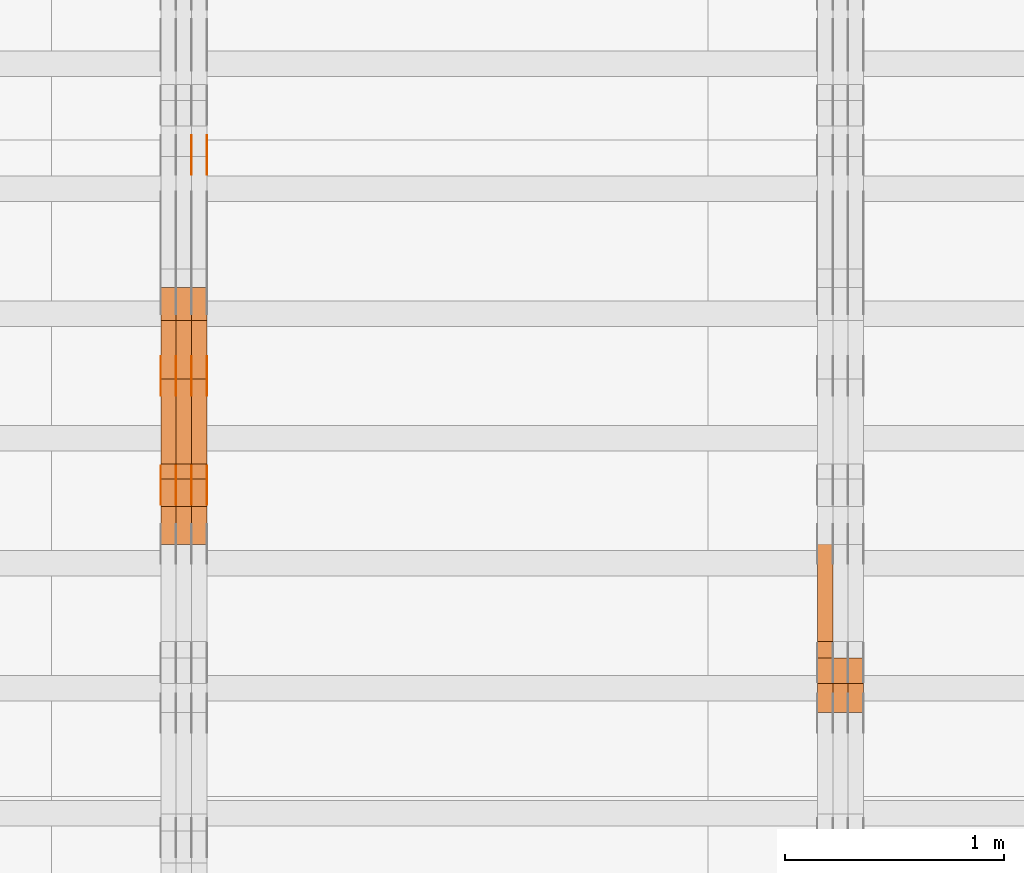
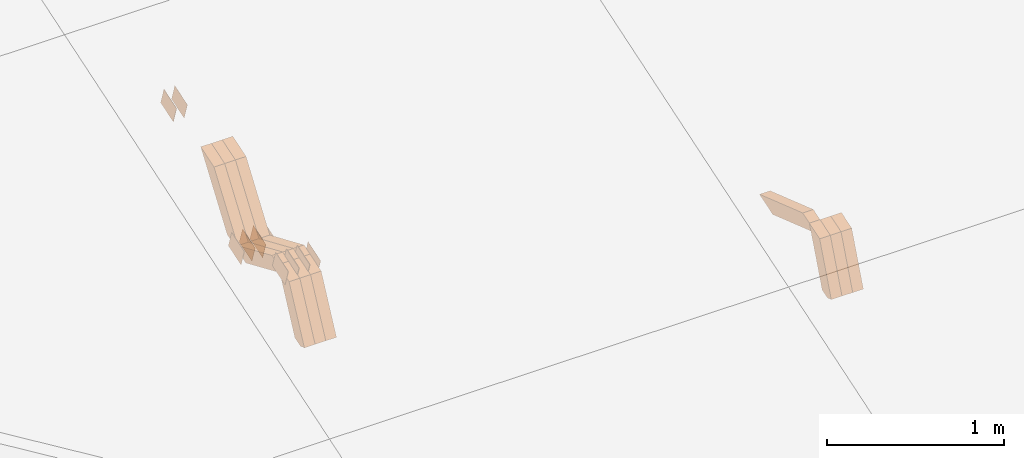
# One storey, part 270 of 385: 28 proxies.
"""IFC2X3 building model written with IfcOpenShell, lengths in millimetres."""

from ifc_helpers import new_model, entity, si_unit, converted_unit, derived_unit, direction, frame, origin, place, context, subcontext, project, spatial, polyline, outline, extrude, source, transform, mapped, material, type_object, type_shapes, element, save


model = new_model("IFC2X3")

# Units and contexts
model_context = context("Model", 3, precision=0.01, world=origin(), true_north=direction((6.12303176911189e-17, 1.0)))
body_context = subcontext(model_context, "Body", "Model", "MODEL_VIEW")
ifc_project = project(units=[si_unit("LENGTHUNIT", "METRE", prefix="MILLI"), si_unit("AREAUNIT", "SQUARE_METRE"), si_unit("VOLUMEUNIT", "CUBIC_METRE"), converted_unit("PLANEANGLEUNIT", "DEGREE", entity("IfcRatioMeasure", 0.0174532925199433), si_unit("PLANEANGLEUNIT", "RADIAN"), dimensions=[0, 0, 0, 0, 0, 0, 0]), si_unit("MASSUNIT", "GRAM", prefix="KILO"), derived_unit("MASSDENSITYUNIT", [(si_unit("MASSUNIT", "GRAM", prefix="KILO"), 1), (si_unit("LENGTHUNIT", "METRE"), -3)]), si_unit("TIMEUNIT", "SECOND"), si_unit("FREQUENCYUNIT", "HERTZ"), si_unit("THERMODYNAMICTEMPERATUREUNIT", "DEGREE_CELSIUS"), derived_unit("THERMALTRANSMITTANCEUNIT", [(si_unit("MASSUNIT", "GRAM", prefix="KILO"), 1), (si_unit("THERMODYNAMICTEMPERATUREUNIT", "KELVIN"), -1), (si_unit("TIMEUNIT", "SECOND"), -3)]), derived_unit("VOLUMETRICFLOWRATEUNIT", [(si_unit("LENGTHUNIT", "METRE"), 3), (si_unit("TIMEUNIT", "SECOND"), -1)]), si_unit("ELECTRICCURRENTUNIT", "AMPERE"), si_unit("ELECTRICVOLTAGEUNIT", "VOLT"), si_unit("POWERUNIT", "WATT"), si_unit("FORCEUNIT", "NEWTON", prefix="KILO"), si_unit("ILLUMINANCEUNIT", "LUX"), si_unit("LUMINOUSFLUXUNIT", "LUMEN"), si_unit("LUMINOUSINTENSITYUNIT", "CANDELA"), derived_unit("USERDEFINED", [(si_unit("MASSUNIT", "GRAM", prefix="KILO"), -1), (si_unit("LENGTHUNIT", "METRE"), -2), (si_unit("TIMEUNIT", "SECOND"), 3), (si_unit("LUMINOUSFLUXUNIT", "LUMEN"), 1)]), derived_unit("LINEARVELOCITYUNIT", [(si_unit("LENGTHUNIT", "METRE"), 1), (si_unit("TIMEUNIT", "SECOND"), -1)]), si_unit("PRESSUREUNIT", "PASCAL"), derived_unit("USERDEFINED", [(si_unit("LENGTHUNIT", "METRE"), -2), (si_unit("MASSUNIT", "GRAM", prefix="KILO"), 1), (si_unit("TIMEUNIT", "SECOND"), -2)])], contexts=[model_context])

# Site, building, storey
site_placement = place(None, origin())
site = spatial("IfcSite", under=ifc_project, at=site_placement, CompositionType="ELEMENT")
building_placement = place(site_placement, origin())
building = spatial("IfcBuilding", under=site, at=building_placement, CompositionType="ELEMENT")
storey_placement = place(building_placement, origin())
storey = spatial("IfcBuildingStorey", under=building, at=storey_placement, Name="Default", CompositionType="ELEMENT", Elevation=0.0)

# Proxies
ifc_material_1 = material(Name="IfcSurfaceStyle #528020")
building_element_proxy_type_1 = type_object("IfcBuildingElementProxyType", Name="T1-W19 528018", PredefinedType="NOTDEFINED", material=ifc_material_1)
shared_shape_1 = source(origin(), body_context, "Body", "SweptSolid", [
    extrude(outline(polyline([(-234.986199656822, -47.5000587840676), (221.224626701627, -47.5000587840676), (219.29748584664, -9.04449542012076e-05), (156.014457007826, 47.5001040065446), (-361.550369899272, 47.5001040065447), (-234.986199656822, -47.5000587840676)])), frame((221.224626701627, 47.5001108598228, 0.0), z_axis=(0.0, 0.0, 1.0), x_axis=(-1.0, 0.0, 0.0)), (0.0, 0.0, 1.0), 70.0),
])
type_shapes(building_element_proxy_type_1, [shared_shape_1])
proxy_1_placement = place(building_placement, frame((45245.0, 6342.40425701111, 1541.63383639481), z_axis=(-1.0, 0.0, 0.0), x_axis=(0.0, 0.9461301511345, -0.323786561046329)))
element("IfcBuildingElementProxy", 1, at=proxy_1_placement, inside=storey, type_object=building_element_proxy_type_1, material=ifc_material_1, Name="T1-W19", context=body_context, shape_type="MappedRepresentation", body=[
    mapped(shared_shape_1, transform((0.0, 0.0, 0.0), scale=1.0)),
])
ifc_material_2 = material(Name="IfcSurfaceStyle #527756")
building_element_proxy_type_2 = type_object("IfcBuildingElementProxyType", Name="T1-W46 527754", PredefinedType="NOTDEFINED", material=ifc_material_2)
shared_shape_2 = source(origin(), body_context, "Body", "SweptSolid", [
    extrude(outline(polyline([(-272.224583017384, -47.5002947748381), (128.798007350946, -47.5002947748382), (167.560249082673, 0.000339032424879266), (170.567132940603, 47.500741369691), (-194.700806356838, 47.4995091475604), (-272.224583017384, -47.5002947748381)])), frame((170.567293182179, 47.5001659655231, 0.0), z_axis=(0.0, 0.0, 1.0), x_axis=(-1.0, 3.37347464168628e-06, 0.0)), (0.0, 0.0, 1.0), 70.0),
])
type_shapes(building_element_proxy_type_2, [shared_shape_2])
proxy_2_placement = place(building_placement, frame((45385.0, 6080.04687500001, 1117.66674804688), z_axis=(-1.0, 0.0, 0.0), x_axis=(0.0, 0.361885618189232, 0.93222250527854)))
element("IfcBuildingElementProxy", 2, at=proxy_2_placement, inside=storey, type_object=building_element_proxy_type_2, material=ifc_material_2, Name="T1-W46", context=body_context, shape_type="MappedRepresentation", body=[
    mapped(shared_shape_2, transform((0.0, 0.0, 0.0), scale=1.0)),
])
ifc_material_3 = material(Name="IfcSurfaceStyle #527690")
building_element_proxy_type_3 = type_object("IfcBuildingElementProxyType", Name="T1-W46 527688", PredefinedType="NOTDEFINED", material=ifc_material_3)
shared_shape_3 = source(origin(), body_context, "Body", "SweptSolid", [
    extrude(outline(polyline([(-272.224583017384, -47.5002947748381), (128.798007350946, -47.5002947748382), (167.560249082673, 0.000339032424879266), (170.567132940603, 47.500741369691), (-194.700806356838, 47.4995091475604), (-272.224583017384, -47.5002947748381)])), frame((170.567293182179, 47.5001659655231, 0.0), z_axis=(0.0, 0.0, 1.0), x_axis=(-1.0, 3.37347464168628e-06, 0.0)), (0.0, 0.0, 1.0), 70.0),
])
type_shapes(building_element_proxy_type_3, [shared_shape_3])
proxy_3_placement = place(building_placement, frame((45315.0, 6080.04687500001, 1117.66674804688), z_axis=(-1.0, 0.0, 0.0), x_axis=(0.0, 0.361885618189232, 0.93222250527854)))
element("IfcBuildingElementProxy", 3, at=proxy_3_placement, inside=storey, type_object=building_element_proxy_type_3, material=ifc_material_3, Name="T1-W46", context=body_context, shape_type="MappedRepresentation", body=[
    mapped(shared_shape_3, transform((0.0, 0.0, 0.0), scale=1.0)),
])
ifc_material_4 = material(Name="IfcSurfaceStyle #527624")
building_element_proxy_type_4 = type_object("IfcBuildingElementProxyType", Name="T1-W46 527622", PredefinedType="NOTDEFINED", material=ifc_material_4)
shared_shape_4 = source(origin(), body_context, "Body", "SweptSolid", [
    extrude(outline(polyline([(-272.224583017384, -47.5002947748381), (128.798007350946, -47.5002947748382), (167.560249082673, 0.000339032424879266), (170.567132940603, 47.500741369691), (-194.700806356838, 47.4995091475604), (-272.224583017384, -47.5002947748381)])), frame((170.567293182179, 47.5001659655231, 0.0), z_axis=(0.0, 0.0, 1.0), x_axis=(-1.0, 3.37347464168628e-06, 0.0)), (0.0, 0.0, 1.0), 70.0),
])
type_shapes(building_element_proxy_type_4, [shared_shape_4])
proxy_4_placement = place(building_placement, frame((45245.0, 6080.04687500001, 1117.66674804688), z_axis=(-1.0, 0.0, 0.0), x_axis=(0.0, 0.361885618189232, 0.93222250527854)))
element("IfcBuildingElementProxy", 4, at=proxy_4_placement, inside=storey, type_object=building_element_proxy_type_4, material=ifc_material_4, Name="T1-W46", context=body_context, shape_type="MappedRepresentation", body=[
    mapped(shared_shape_4, transform((0.0, 0.0, 0.0), scale=1.0)),
])
ifc_material_5 = material(Name="IfcSurfaceStyle #522790")
building_element_proxy_type_5 = type_object("IfcBuildingElementProxyType", PredefinedType="NOTDEFINED", material=ifc_material_5)
shared_shape_5 = source(origin(), body_context, "Body", "SweptSolid", [
    extrude(outline(polyline([(-74.9998565677179, -60.000059685226), (74.9998794200128, -60.000059685226), (74.9998565677179, 60.000059685226), (-74.9998794200128, 60.000059685226), (-74.9998565677179, -60.000059685226)])), frame((75.0001976720505, 60.000059685226, 0.0), z_axis=(0.0, 0.0, 1.0), x_axis=(-1.0, 0.0, 0.0)), (0.0, 0.0, 1.0), 1.3),
])
type_shapes(building_element_proxy_type_5, [shared_shape_5])
proxy_5_placement = place(building_placement, frame((42386.3, 8537.53090236182, 1950.11166041942), z_axis=(-1.0, 0.0, 0.0), x_axis=(0.0, 0.951056516295124, 0.309016994375039)))
element("IfcBuildingElementProxy", 5, at=proxy_5_placement, inside=storey, type_object=building_element_proxy_type_5, material=ifc_material_5, context=body_context, shape_type="MappedRepresentation", body=[
    mapped(shared_shape_5, transform((0.0, 0.0, 0.0), scale=1.0)),
])
ifc_material_6 = material(Name="IfcSurfaceStyle #522733")
building_element_proxy_type_6 = type_object("IfcBuildingElementProxyType", PredefinedType="NOTDEFINED", material=ifc_material_6)
shared_shape_6 = source(origin(), body_context, "Body", "SweptSolid", [
    extrude(outline(polyline([(-74.9998565677179, -60.000059685226), (74.9998794200128, -60.000059685226), (74.9998565677179, 60.000059685226), (-74.9998794200128, 60.000059685226), (-74.9998565677179, -60.000059685226)])), frame((75.0001976720505, 60.000059685226, 0.0), z_axis=(0.0, 0.0, 1.0), x_axis=(-1.0, 0.0, 0.0)), (0.0, 0.0, 1.0), 1.3),
])
type_shapes(building_element_proxy_type_6, [shared_shape_6])
proxy_6_placement = place(building_placement, frame((42315.0, 8537.53090236182, 1950.11166041942), z_axis=(-1.0, 0.0, 0.0), x_axis=(0.0, 0.951056516295124, 0.309016994375039)))
element("IfcBuildingElementProxy", 6, at=proxy_6_placement, inside=storey, type_object=building_element_proxy_type_6, material=ifc_material_6, context=body_context, shape_type="MappedRepresentation", body=[
    mapped(shared_shape_6, transform((0.0, 0.0, 0.0), scale=1.0)),
])
ifc_material_7 = material(Name="IfcSurfaceStyle #522676")
building_element_proxy_type_7 = type_object("IfcBuildingElementProxyType", PredefinedType="NOTDEFINED", material=ifc_material_7)
shared_shape_7 = source(origin(), body_context, "Body", "SweptSolid", [
    extrude(outline(polyline([(-74.9998565677179, -60.000059685226), (74.9998794200128, -60.000059685226), (74.9998565677179, 60.000059685226), (-74.9998794200128, 60.000059685226), (-74.9998565677179, -60.000059685226)])), frame((75.0001976720505, 60.000059685226, 0.0), z_axis=(0.0, 0.0, 1.0), x_axis=(-1.0, 0.0, 0.0)), (0.0, 0.0, 1.0), 1.3),
])
type_shapes(building_element_proxy_type_7, [shared_shape_7])
proxy_7_placement = place(building_placement, frame((42316.3, 8537.53090236182, 1950.11166041942), z_axis=(-1.0, 0.0, 0.0), x_axis=(0.0, 0.951056516295124, 0.309016994375039)))
element("IfcBuildingElementProxy", 7, at=proxy_7_placement, inside=storey, type_object=building_element_proxy_type_7, material=ifc_material_7, context=body_context, shape_type="MappedRepresentation", body=[
    mapped(shared_shape_7, transform((0.0, 0.0, 0.0), scale=1.0)),
])
ifc_material_8 = material(Name="IfcSurfaceStyle #517660")
building_element_proxy_type_8 = type_object("IfcBuildingElementProxyType", PredefinedType="NOTDEFINED", material=ifc_material_8)
shared_shape_8 = source(origin(), body_context, "Body", "SweptSolid", [
    extrude(outline(polyline([(-74.9998565677169, -60.0000596852269), (74.9998794200137, -60.0000596852269), (74.9998565677151, 60.0000596852269), (-74.9998794200119, 60.0000596852269), (-74.9998565677169, -60.0000596852269)])), frame((74.9998794200137, 60.0000596852269, 0.0), z_axis=(0.0, 0.0, 1.0), x_axis=(-1.0, 0.0, 0.0)), (0.0, 0.0, 1.0), 1.3),
])
type_shapes(building_element_proxy_type_8, [shared_shape_8])
proxy_8_placement = place(building_placement, frame((42386.3, 7527.6269081625, 1621.97418552253), z_axis=(-1.0, 0.0, 0.0), x_axis=(0.0, 0.951056516295124, 0.309016994375039)))
element("IfcBuildingElementProxy", 8, at=proxy_8_placement, inside=storey, type_object=building_element_proxy_type_8, material=ifc_material_8, context=body_context, shape_type="MappedRepresentation", body=[
    mapped(shared_shape_8, transform((0.0, 0.0, 0.0), scale=1.0)),
])
ifc_material_9 = material(Name="IfcSurfaceStyle #517603")
building_element_proxy_type_9 = type_object("IfcBuildingElementProxyType", PredefinedType="NOTDEFINED", material=ifc_material_9)
shared_shape_9 = source(origin(), body_context, "Body", "SweptSolid", [
    extrude(outline(polyline([(-74.9998565677169, -60.0000596852269), (74.9998794200137, -60.0000596852269), (74.9998565677151, 60.0000596852269), (-74.9998794200119, 60.0000596852269), (-74.9998565677169, -60.0000596852269)])), frame((74.9998794200137, 60.0000596852269, 0.0), z_axis=(0.0, 0.0, 1.0), x_axis=(-1.0, 0.0, 0.0)), (0.0, 0.0, 1.0), 1.3),
])
type_shapes(building_element_proxy_type_9, [shared_shape_9])
proxy_9_placement = place(building_placement, frame((42315.0, 7527.6269081625, 1621.97418552253), z_axis=(-1.0, 0.0, 0.0), x_axis=(0.0, 0.951056516295124, 0.309016994375039)))
element("IfcBuildingElementProxy", 9, at=proxy_9_placement, inside=storey, type_object=building_element_proxy_type_9, material=ifc_material_9, context=body_context, shape_type="MappedRepresentation", body=[
    mapped(shared_shape_9, transform((0.0, 0.0, 0.0), scale=1.0)),
])
ifc_material_10 = material(Name="IfcSurfaceStyle #517546")
building_element_proxy_type_10 = type_object("IfcBuildingElementProxyType", PredefinedType="NOTDEFINED", material=ifc_material_10)
shared_shape_10 = source(origin(), body_context, "Body", "SweptSolid", [
    extrude(outline(polyline([(-74.9998565677169, -60.0000596852269), (74.9998794200137, -60.0000596852269), (74.9998565677151, 60.0000596852269), (-74.9998794200119, 60.0000596852269), (-74.9998565677169, -60.0000596852269)])), frame((74.9998794200137, 60.0000596852269, 0.0), z_axis=(0.0, 0.0, 1.0), x_axis=(-1.0, 0.0, 0.0)), (0.0, 0.0, 1.0), 1.3),
])
type_shapes(building_element_proxy_type_10, [shared_shape_10])
proxy_10_placement = place(building_placement, frame((42316.3, 7527.6269081625, 1621.97418552253), z_axis=(-1.0, 0.0, 0.0), x_axis=(0.0, 0.951056516295124, 0.309016994375039)))
element("IfcBuildingElementProxy", 10, at=proxy_10_placement, inside=storey, type_object=building_element_proxy_type_10, material=ifc_material_10, context=body_context, shape_type="MappedRepresentation", body=[
    mapped(shared_shape_10, transform((0.0, 0.0, 0.0), scale=1.0)),
])
ifc_material_11 = material(Name="IfcSurfaceStyle #517489")
building_element_proxy_type_11 = type_object("IfcBuildingElementProxyType", PredefinedType="NOTDEFINED", material=ifc_material_11)
shared_shape_11 = source(origin(), body_context, "Body", "SweptSolid", [
    extrude(outline(polyline([(-74.9998565677169, -60.0000596852269), (74.9998794200137, -60.0000596852269), (74.9998565677151, 60.0000596852269), (-74.9998794200119, 60.0000596852269), (-74.9998565677169, -60.0000596852269)])), frame((74.9998794200137, 60.0000596852269, 0.0), z_axis=(0.0, 0.0, 1.0), x_axis=(-1.0, 0.0, 0.0)), (0.0, 0.0, 1.0), 1.29999999999999),
])
type_shapes(building_element_proxy_type_11, [shared_shape_11])
proxy_11_placement = place(building_placement, frame((42245.0, 7527.6269081625, 1621.97418552253), z_axis=(-1.0, 0.0, 0.0), x_axis=(0.0, 0.951056516295124, 0.309016994375039)))
element("IfcBuildingElementProxy", 11, at=proxy_11_placement, inside=storey, type_object=building_element_proxy_type_11, material=ifc_material_11, context=body_context, shape_type="MappedRepresentation", body=[
    mapped(shared_shape_11, transform((0.0, 0.0, 0.0), scale=1.0)),
])
ifc_material_12 = material(Name="IfcSurfaceStyle #517432")
building_element_proxy_type_12 = type_object("IfcBuildingElementProxyType", PredefinedType="NOTDEFINED", material=ifc_material_12)
shared_shape_12 = source(origin(), body_context, "Body", "SweptSolid", [
    extrude(outline(polyline([(-74.9998565677169, -60.0000596852269), (74.9998794200137, -60.0000596852269), (74.9998565677151, 60.0000596852269), (-74.9998794200119, 60.0000596852269), (-74.9998565677169, -60.0000596852269)])), frame((74.9998794200137, 60.0000596852269, 0.0), z_axis=(0.0, 0.0, 1.0), x_axis=(-1.0, 0.0, 0.0)), (0.0, 0.0, 1.0), 1.29999999999999),
])
type_shapes(building_element_proxy_type_12, [shared_shape_12])
proxy_12_placement = place(building_placement, frame((42246.3, 7527.6269081625, 1621.97418552253), z_axis=(-1.0, 0.0, 0.0), x_axis=(0.0, 0.951056516295124, 0.309016994375039)))
element("IfcBuildingElementProxy", 12, at=proxy_12_placement, inside=storey, type_object=building_element_proxy_type_12, material=ifc_material_12, context=body_context, shape_type="MappedRepresentation", body=[
    mapped(shared_shape_12, transform((0.0, 0.0, 0.0), scale=1.0)),
])
ifc_material_13 = material(Name="IfcSurfaceStyle #517375")
building_element_proxy_type_13 = type_object("IfcBuildingElementProxyType", PredefinedType="NOTDEFINED", material=ifc_material_13)
shared_shape_13 = source(origin(), body_context, "Body", "SweptSolid", [
    extrude(outline(polyline([(-74.9998565677169, -60.0000596852269), (74.9998794200137, -60.0000596852269), (74.9998565677151, 60.0000596852269), (-74.9998794200119, 60.0000596852269), (-74.9998565677169, -60.0000596852269)])), frame((74.9998794200137, 60.0000596852269, 0.0), z_axis=(0.0, 0.0, 1.0), x_axis=(-1.0, 0.0, 0.0)), (0.0, 0.0, 1.0), 1.29999999999999),
])
type_shapes(building_element_proxy_type_13, [shared_shape_13])
proxy_13_placement = place(building_placement, frame((42175.0, 7527.6269081625, 1621.97418552253), z_axis=(-1.0, 0.0, 0.0), x_axis=(0.0, 0.951056516295124, 0.309016994375039)))
element("IfcBuildingElementProxy", 13, at=proxy_13_placement, inside=storey, type_object=building_element_proxy_type_13, material=ifc_material_13, context=body_context, shape_type="MappedRepresentation", body=[
    mapped(shared_shape_13, transform((0.0, 0.0, 0.0), scale=1.0)),
])
ifc_material_14 = material(Name="IfcSurfaceStyle #507400")
building_element_proxy_type_14 = type_object("IfcBuildingElementProxyType", PredefinedType="NOTDEFINED", material=ifc_material_14)
shared_shape_14 = source(origin(), body_context, "Body", "SweptSolid", [
    extrude(outline(polyline([(-74.9998565677233, -60.0000596852342), (74.9998794200074, -60.0000596852342), (74.9998565677233, 60.0000596852342), (-74.9998794200074, 60.0000596852342), (-74.9998565677233, -60.0000596852342)])), frame((74.9998794200073, 60.0000596852342, 0.0), z_axis=(0.0, 0.0, 1.0), x_axis=(-1.0, 0.0, 0.0)), (0.0, 0.0, 1.0), 1.3),
])
type_shapes(building_element_proxy_type_14, [shared_shape_14])
proxy_14_placement = place(building_placement, frame((42386.3, 7029.15620503751, 1786.70025974129), z_axis=(-1.0, 0.0, 0.0), x_axis=(0.0, 0.951056516295154, 0.309016994374948)))
element("IfcBuildingElementProxy", 14, at=proxy_14_placement, inside=storey, type_object=building_element_proxy_type_14, material=ifc_material_14, context=body_context, shape_type="MappedRepresentation", body=[
    mapped(shared_shape_14, transform((0.0, 0.0, 0.0), scale=1.0)),
])
ifc_material_15 = material(Name="IfcSurfaceStyle #507343")
building_element_proxy_type_15 = type_object("IfcBuildingElementProxyType", PredefinedType="NOTDEFINED", material=ifc_material_15)
shared_shape_15 = source(origin(), body_context, "Body", "SweptSolid", [
    extrude(outline(polyline([(-74.9998565677233, -60.0000596852342), (74.9998794200074, -60.0000596852342), (74.9998565677233, 60.0000596852342), (-74.9998794200074, 60.0000596852342), (-74.9998565677233, -60.0000596852342)])), frame((74.9998794200073, 60.0000596852342, 0.0), z_axis=(0.0, 0.0, 1.0), x_axis=(-1.0, 0.0, 0.0)), (0.0, 0.0, 1.0), 1.3),
])
type_shapes(building_element_proxy_type_15, [shared_shape_15])
proxy_15_placement = place(building_placement, frame((42315.0, 7029.15620503751, 1786.70025974129), z_axis=(-1.0, 0.0, 0.0), x_axis=(0.0, 0.951056516295154, 0.309016994374948)))
element("IfcBuildingElementProxy", 15, at=proxy_15_placement, inside=storey, type_object=building_element_proxy_type_15, material=ifc_material_15, context=body_context, shape_type="MappedRepresentation", body=[
    mapped(shared_shape_15, transform((0.0, 0.0, 0.0), scale=1.0)),
])
ifc_material_16 = material(Name="IfcSurfaceStyle #507286")
building_element_proxy_type_16 = type_object("IfcBuildingElementProxyType", PredefinedType="NOTDEFINED", material=ifc_material_16)
shared_shape_16 = source(origin(), body_context, "Body", "SweptSolid", [
    extrude(outline(polyline([(-74.9998565677233, -60.0000596852342), (74.9998794200074, -60.0000596852342), (74.9998565677233, 60.0000596852342), (-74.9998794200074, 60.0000596852342), (-74.9998565677233, -60.0000596852342)])), frame((74.9998794200073, 60.0000596852342, 0.0), z_axis=(0.0, 0.0, 1.0), x_axis=(-1.0, 0.0, 0.0)), (0.0, 0.0, 1.0), 1.3),
])
type_shapes(building_element_proxy_type_16, [shared_shape_16])
proxy_16_placement = place(building_placement, frame((42316.3, 7029.15620503751, 1786.70025974129), z_axis=(-1.0, 0.0, 0.0), x_axis=(0.0, 0.951056516295154, 0.309016994374948)))
element("IfcBuildingElementProxy", 16, at=proxy_16_placement, inside=storey, type_object=building_element_proxy_type_16, material=ifc_material_16, context=body_context, shape_type="MappedRepresentation", body=[
    mapped(shared_shape_16, transform((0.0, 0.0, 0.0), scale=1.0)),
])
ifc_material_17 = material(Name="IfcSurfaceStyle #507229")
building_element_proxy_type_17 = type_object("IfcBuildingElementProxyType", PredefinedType="NOTDEFINED", material=ifc_material_17)
shared_shape_17 = source(origin(), body_context, "Body", "SweptSolid", [
    extrude(outline(polyline([(-74.9998565677233, -60.0000596852342), (74.9998794200074, -60.0000596852342), (74.9998565677233, 60.0000596852342), (-74.9998794200074, 60.0000596852342), (-74.9998565677233, -60.0000596852342)])), frame((74.9998794200073, 60.0000596852342, 0.0), z_axis=(0.0, 0.0, 1.0), x_axis=(-1.0, 0.0, 0.0)), (0.0, 0.0, 1.0), 1.29999999999999),
])
type_shapes(building_element_proxy_type_17, [shared_shape_17])
proxy_17_placement = place(building_placement, frame((42245.0, 7029.15620503751, 1786.70025974129), z_axis=(-1.0, 0.0, 0.0), x_axis=(0.0, 0.951056516295154, 0.309016994374948)))
element("IfcBuildingElementProxy", 17, at=proxy_17_placement, inside=storey, type_object=building_element_proxy_type_17, material=ifc_material_17, context=body_context, shape_type="MappedRepresentation", body=[
    mapped(shared_shape_17, transform((0.0, 0.0, 0.0), scale=1.0)),
])
ifc_material_18 = material(Name="IfcSurfaceStyle #507172")
building_element_proxy_type_18 = type_object("IfcBuildingElementProxyType", PredefinedType="NOTDEFINED", material=ifc_material_18)
shared_shape_18 = source(origin(), body_context, "Body", "SweptSolid", [
    extrude(outline(polyline([(-74.9998565677233, -60.0000596852342), (74.9998794200074, -60.0000596852342), (74.9998565677233, 60.0000596852342), (-74.9998794200074, 60.0000596852342), (-74.9998565677233, -60.0000596852342)])), frame((74.9998794200073, 60.0000596852342, 0.0), z_axis=(0.0, 0.0, 1.0), x_axis=(-1.0, 0.0, 0.0)), (0.0, 0.0, 1.0), 1.29999999999999),
])
type_shapes(building_element_proxy_type_18, [shared_shape_18])
proxy_18_placement = place(building_placement, frame((42246.3, 7029.15620503751, 1786.70025974129), z_axis=(-1.0, 0.0, 0.0), x_axis=(0.0, 0.951056516295154, 0.309016994374948)))
element("IfcBuildingElementProxy", 18, at=proxy_18_placement, inside=storey, type_object=building_element_proxy_type_18, material=ifc_material_18, context=body_context, shape_type="MappedRepresentation", body=[
    mapped(shared_shape_18, transform((0.0, 0.0, 0.0), scale=1.0)),
])
ifc_material_19 = material(Name="IfcSurfaceStyle #507115")
building_element_proxy_type_19 = type_object("IfcBuildingElementProxyType", PredefinedType="NOTDEFINED", material=ifc_material_19)
shared_shape_19 = source(origin(), body_context, "Body", "SweptSolid", [
    extrude(outline(polyline([(-74.9998565677233, -60.0000596852342), (74.9998794200074, -60.0000596852342), (74.9998565677233, 60.0000596852342), (-74.9998794200074, 60.0000596852342), (-74.9998565677233, -60.0000596852342)])), frame((74.9998794200073, 60.0000596852342, 0.0), z_axis=(0.0, 0.0, 1.0), x_axis=(-1.0, 0.0, 0.0)), (0.0, 0.0, 1.0), 1.29999999999999),
])
type_shapes(building_element_proxy_type_19, [shared_shape_19])
proxy_19_placement = place(building_placement, frame((42175.0, 7029.15620503751, 1786.70025974129), z_axis=(-1.0, 0.0, 0.0), x_axis=(0.0, 0.951056516295154, 0.309016994374948)))
element("IfcBuildingElementProxy", 19, at=proxy_19_placement, inside=storey, type_object=building_element_proxy_type_19, material=ifc_material_19, context=body_context, shape_type="MappedRepresentation", body=[
    mapped(shared_shape_19, transform((0.0, 0.0, 0.0), scale=1.0)),
])
ifc_material_20 = material(Name="IfcSurfaceStyle #494908")
building_element_proxy_type_20 = type_object("IfcBuildingElementProxyType", Name="T1-W17 494906", PredefinedType="NOTDEFINED", material=ifc_material_20)
shared_shape_20 = source(origin(), body_context, "Body", "SweptSolid", [
    extrude(outline(polyline([(-364.271754334175, -47.5002955168173), (154.762247185537, -47.5002955168173), (218.32500198375, 4.1746158945366e-05), (228.330650189718, 47.5002746437378), (-237.14614502483, 47.5002746437378), (-364.271754334175, -47.5002955168173)])), frame((228.330650189718, 47.5002746437378, 0.0), z_axis=(0.0, 0.0, 1.0), x_axis=(-1.0, 0.0, 0.0)), (0.0, 0.0, 1.0), 70.0),
])
type_shapes(building_element_proxy_type_20, [shared_shape_20])
proxy_20_placement = place(building_placement, frame((42385.0, 7603.591796875, 1617.27880859375), z_axis=(-1.0, 0.0, 0.0), x_axis=(0.0, 0.576852646364743, 0.816848226038346)))
element("IfcBuildingElementProxy", 20, at=proxy_20_placement, inside=storey, type_object=building_element_proxy_type_20, material=ifc_material_20, Name="T1-W17", context=body_context, shape_type="MappedRepresentation", body=[
    mapped(shared_shape_20, transform((0.0, 0.0, 0.0), scale=1.0)),
])
ifc_material_21 = material(Name="IfcSurfaceStyle #494842")
building_element_proxy_type_21 = type_object("IfcBuildingElementProxyType", Name="T1-W17 494840", PredefinedType="NOTDEFINED", material=ifc_material_21)
shared_shape_21 = source(origin(), body_context, "Body", "SweptSolid", [
    extrude(outline(polyline([(-364.271754334175, -47.5002955168173), (154.762247185537, -47.5002955168173), (218.32500198375, 4.1746158945366e-05), (228.330650189718, 47.5002746437378), (-237.14614502483, 47.5002746437378), (-364.271754334175, -47.5002955168173)])), frame((228.330650189718, 47.5002746437378, 0.0), z_axis=(0.0, 0.0, 1.0), x_axis=(-1.0, 0.0, 0.0)), (0.0, 0.0, 1.0), 70.0),
])
type_shapes(building_element_proxy_type_21, [shared_shape_21])
proxy_21_placement = place(building_placement, frame((42315.0, 7603.591796875, 1617.27880859375), z_axis=(-1.0, 0.0, 0.0), x_axis=(0.0, 0.576852646364743, 0.816848226038346)))
element("IfcBuildingElementProxy", 21, at=proxy_21_placement, inside=storey, type_object=building_element_proxy_type_21, material=ifc_material_21, Name="T1-W17", context=body_context, shape_type="MappedRepresentation", body=[
    mapped(shared_shape_21, transform((0.0, 0.0, 0.0), scale=1.0)),
])
ifc_material_22 = material(Name="IfcSurfaceStyle #494776")
building_element_proxy_type_22 = type_object("IfcBuildingElementProxyType", Name="T1-W17 494774", PredefinedType="NOTDEFINED", material=ifc_material_22)
shared_shape_22 = source(origin(), body_context, "Body", "SweptSolid", [
    extrude(outline(polyline([(-364.271754334175, -47.5002955168173), (154.762247185537, -47.5002955168173), (218.32500198375, 4.1746158945366e-05), (228.330650189718, 47.5002746437378), (-237.14614502483, 47.5002746437378), (-364.271754334175, -47.5002955168173)])), frame((228.330650189718, 47.5002746437378, 0.0), z_axis=(0.0, 0.0, 1.0), x_axis=(-1.0, 0.0, 0.0)), (0.0, 0.0, 1.0), 70.0),
])
type_shapes(building_element_proxy_type_22, [shared_shape_22])
proxy_22_placement = place(building_placement, frame((42245.0, 7603.591796875, 1617.27880859375), z_axis=(-1.0, 0.0, 0.0), x_axis=(0.0, 0.576852646364743, 0.816848226038346)))
element("IfcBuildingElementProxy", 22, at=proxy_22_placement, inside=storey, type_object=building_element_proxy_type_22, material=ifc_material_22, Name="T1-W17", context=body_context, shape_type="MappedRepresentation", body=[
    mapped(shared_shape_22, transform((0.0, 0.0, 0.0), scale=1.0)),
])
ifc_material_23 = material(Name="IfcSurfaceStyle #494512")
building_element_proxy_type_23 = type_object("IfcBuildingElementProxyType", Name="T1-W28 494510", PredefinedType="NOTDEFINED", material=ifc_material_23)
shared_shape_23 = source(origin(), body_context, "Body", "SweptSolid", [
    extrude(outline(polyline([(-217.926999432742, -47.5002417204892), (200.85556309928, -47.5002417204892), (198.503183549447, 8.27993157516647e-05), (144.500539771884, 47.5002003208314), (-325.932286987868, 47.5002003208314), (-217.926999432742, -47.5002417204892)])), frame((200.855855188284, 47.5002003208314, 0.0), z_axis=(0.0, 0.0, 1.0), x_axis=(-1.0, 0.0, 0.0)), (0.0, 0.0, 1.0), 70.0),
])
type_shapes(building_element_proxy_type_23, [shared_shape_23])
proxy_23_placement = place(building_placement, frame((42385.0, 7164.46308589723, 1806.71154838415), z_axis=(-1.0, 0.0, 0.0), x_axis=(0.0, 0.918207947119617, -0.396098681954861)))
element("IfcBuildingElementProxy", 23, at=proxy_23_placement, inside=storey, type_object=building_element_proxy_type_23, material=ifc_material_23, Name="T1-W28", context=body_context, shape_type="MappedRepresentation", body=[
    mapped(shared_shape_23, transform((0.0, 0.0, 0.0), scale=1.0)),
])
ifc_material_24 = material(Name="IfcSurfaceStyle #494446")
building_element_proxy_type_24 = type_object("IfcBuildingElementProxyType", Name="T1-W28 494444", PredefinedType="NOTDEFINED", material=ifc_material_24)
shared_shape_24 = source(origin(), body_context, "Body", "SweptSolid", [
    extrude(outline(polyline([(-217.926999432742, -47.5002417204892), (200.85556309928, -47.5002417204892), (198.503183549447, 8.27993157516647e-05), (144.500539771884, 47.5002003208314), (-325.932286987868, 47.5002003208314), (-217.926999432742, -47.5002417204892)])), frame((200.855855188284, 47.5002003208314, 0.0), z_axis=(0.0, 0.0, 1.0), x_axis=(-1.0, 0.0, 0.0)), (0.0, 0.0, 1.0), 70.0),
])
type_shapes(building_element_proxy_type_24, [shared_shape_24])
proxy_24_placement = place(building_placement, frame((42315.0, 7164.46308589723, 1806.71154838415), z_axis=(-1.0, 0.0, 0.0), x_axis=(0.0, 0.918207947119617, -0.396098681954861)))
element("IfcBuildingElementProxy", 24, at=proxy_24_placement, inside=storey, type_object=building_element_proxy_type_24, material=ifc_material_24, Name="T1-W28", context=body_context, shape_type="MappedRepresentation", body=[
    mapped(shared_shape_24, transform((0.0, 0.0, 0.0), scale=1.0)),
])
ifc_material_25 = material(Name="IfcSurfaceStyle #494380")
building_element_proxy_type_25 = type_object("IfcBuildingElementProxyType", Name="T1-W28 494378", PredefinedType="NOTDEFINED", material=ifc_material_25)
shared_shape_25 = source(origin(), body_context, "Body", "SweptSolid", [
    extrude(outline(polyline([(-217.926999432742, -47.5002417204892), (200.85556309928, -47.5002417204892), (198.503183549447, 8.27993157516647e-05), (144.500539771884, 47.5002003208314), (-325.932286987868, 47.5002003208314), (-217.926999432742, -47.5002417204892)])), frame((200.855855188284, 47.5002003208314, 0.0), z_axis=(0.0, 0.0, 1.0), x_axis=(-1.0, 0.0, 0.0)), (0.0, 0.0, 1.0), 70.0),
])
type_shapes(building_element_proxy_type_25, [shared_shape_25])
proxy_25_placement = place(building_placement, frame((42245.0, 7164.46308589723, 1806.71154838415), z_axis=(-1.0, 0.0, 0.0), x_axis=(0.0, 0.918207947119617, -0.396098681954861)))
element("IfcBuildingElementProxy", 25, at=proxy_25_placement, inside=storey, type_object=building_element_proxy_type_25, material=ifc_material_25, Name="T1-W28", context=body_context, shape_type="MappedRepresentation", body=[
    mapped(shared_shape_25, transform((0.0, 0.0, 0.0), scale=1.0)),
])
ifc_material_26 = material(Name="IfcSurfaceStyle #494116")
building_element_proxy_type_26 = type_object("IfcBuildingElementProxyType", Name="T1-W38 494114", PredefinedType="NOTDEFINED", material=ifc_material_26)
shared_shape_26 = source(origin(), body_context, "Body", "SweptSolid", [
    extrude(outline(polyline([(-298.027186733919, -47.5000251939178), (135.138415004037, -47.5000251939178), (181.282052802132, 0.000918984287993996), (187.347601017465, 47.4995657017738), (-205.740882089715, 47.4995657017739), (-298.027186733919, -47.5000251939178)])), frame((187.347846776827, 47.5001085012031, 0.0), z_axis=(0.0, 0.0, 1.0), x_axis=(-1.0, 0.0, 0.0)), (0.0, 0.0, 1.0), 70.0),
])
type_shapes(building_element_proxy_type_26, [shared_shape_26])
proxy_26_placement = place(building_placement, frame((42385.0, 6848.47987320449, 1368.44362234215), z_axis=(-1.0, 0.0, 0.0), x_axis=(0.0, 0.441034274474743, 0.897490261082836)))
element("IfcBuildingElementProxy", 26, at=proxy_26_placement, inside=storey, type_object=building_element_proxy_type_26, material=ifc_material_26, Name="T1-W38", context=body_context, shape_type="MappedRepresentation", body=[
    mapped(shared_shape_26, transform((0.0, 0.0, 0.0), scale=1.0)),
])
ifc_material_27 = material(Name="IfcSurfaceStyle #494050")
building_element_proxy_type_27 = type_object("IfcBuildingElementProxyType", Name="T1-W38 494048", PredefinedType="NOTDEFINED", material=ifc_material_27)
shared_shape_27 = source(origin(), body_context, "Body", "SweptSolid", [
    extrude(outline(polyline([(-298.027186733919, -47.5000251939178), (135.138415004037, -47.5000251939178), (181.282052802132, 0.000918984287993996), (187.347601017465, 47.4995657017738), (-205.740882089715, 47.4995657017739), (-298.027186733919, -47.5000251939178)])), frame((187.347846776827, 47.5001085012031, 0.0), z_axis=(0.0, 0.0, 1.0), x_axis=(-1.0, 0.0, 0.0)), (0.0, 0.0, 1.0), 70.0),
])
type_shapes(building_element_proxy_type_27, [shared_shape_27])
proxy_27_placement = place(building_placement, frame((42315.0, 6848.47987320449, 1368.44362234215), z_axis=(-1.0, 0.0, 0.0), x_axis=(0.0, 0.441034274474743, 0.897490261082836)))
element("IfcBuildingElementProxy", 27, at=proxy_27_placement, inside=storey, type_object=building_element_proxy_type_27, material=ifc_material_27, Name="T1-W38", context=body_context, shape_type="MappedRepresentation", body=[
    mapped(shared_shape_27, transform((0.0, 0.0, 0.0), scale=1.0)),
])
ifc_material_28 = material(Name="IfcSurfaceStyle #493984")
building_element_proxy_type_28 = type_object("IfcBuildingElementProxyType", Name="T1-W38 493982", PredefinedType="NOTDEFINED", material=ifc_material_28)
shared_shape_28 = source(origin(), body_context, "Body", "SweptSolid", [
    extrude(outline(polyline([(-298.027186733919, -47.5000251939178), (135.138415004037, -47.5000251939178), (181.282052802132, 0.000918984287993996), (187.347601017465, 47.4995657017738), (-205.740882089715, 47.4995657017739), (-298.027186733919, -47.5000251939178)])), frame((187.347846776827, 47.5001085012031, 0.0), z_axis=(0.0, 0.0, 1.0), x_axis=(-1.0, 0.0, 0.0)), (0.0, 0.0, 1.0), 70.0),
])
type_shapes(building_element_proxy_type_28, [shared_shape_28])
proxy_28_placement = place(building_placement, frame((42245.0, 6848.47987320449, 1368.44362234215), z_axis=(-1.0, 0.0, 0.0), x_axis=(0.0, 0.441034274474743, 0.897490261082836)))
element("IfcBuildingElementProxy", 28, at=proxy_28_placement, inside=storey, type_object=building_element_proxy_type_28, material=ifc_material_28, Name="T1-W38", context=body_context, shape_type="MappedRepresentation", body=[
    mapped(shared_shape_28, transform((0.0, 0.0, 0.0), scale=1.0)),
])

save(model, "model.ifc")
